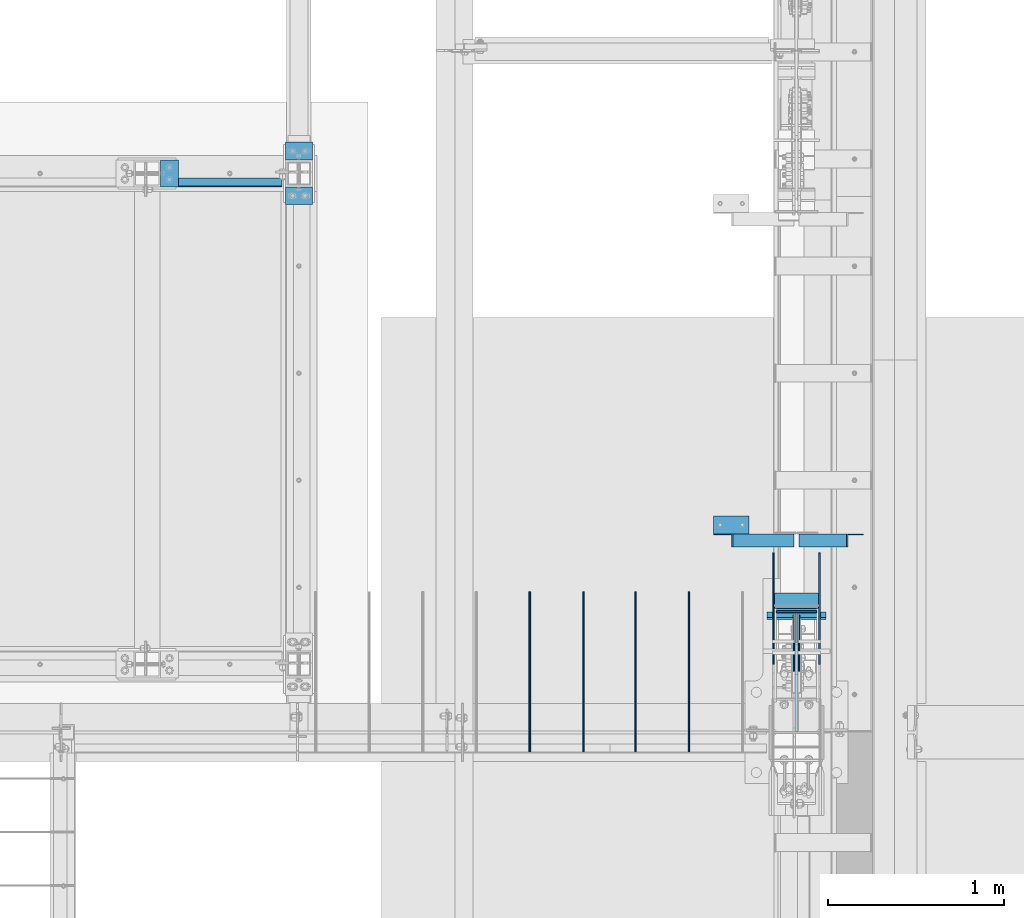
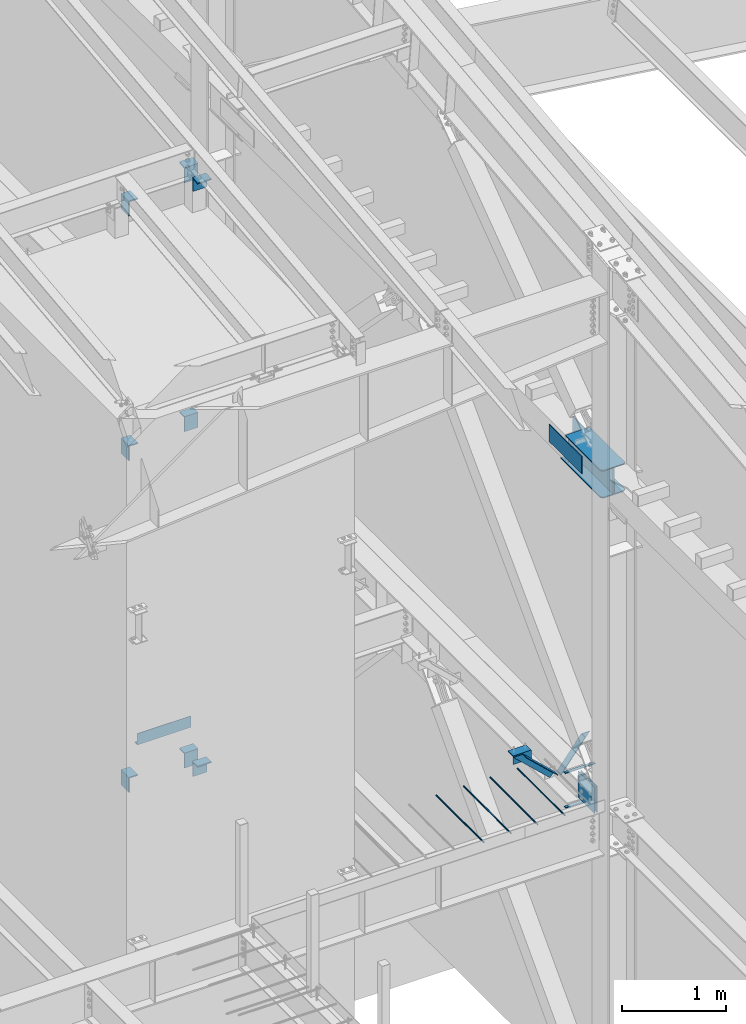
# One storey, part 825 of 1179: 24 beams, 2 members, 20 elements without a shape of their own.
"""IFC2X3 building model written with IfcOpenShell, lengths in millimetres."""

from ifc_helpers import new_model, si_unit, frame, origin_with_axes, place, context, subcontext, project, spatial, faceted_brep, material, type_object, element, aggregate, save


model = new_model("IFC2X3")

# Units and contexts
model_context = context("Model", 3, precision=1e-05, world=origin_with_axes())
body_context = subcontext(model_context, "Body", "Model", "MODEL_VIEW")
ifc_project = project(units=[si_unit("LENGTHUNIT", "METRE", prefix="MILLI"), si_unit("AREAUNIT", "SQUARE_METRE"), si_unit("VOLUMEUNIT", "CUBIC_METRE"), si_unit("MASSUNIT", "GRAM", prefix="KILO"), si_unit("TIMEUNIT", "SECOND"), si_unit("PLANEANGLEUNIT", "RADIAN"), si_unit("SOLIDANGLEUNIT", "STERADIAN"), si_unit("THERMODYNAMICTEMPERATUREUNIT", "DEGREE_CELSIUS"), si_unit("LUMINOUSINTENSITYUNIT", "LUMEN")], contexts=[model_context])

# Site, building, storey
site_placement = place(None, origin_with_axes())
site = spatial("IfcSite", under=ifc_project, at=site_placement, CompositionType="ELEMENT")
building_placement = place(site_placement, origin_with_axes())
building = spatial("IfcBuilding", under=site, at=building_placement, Name="Undefined", CompositionType="ELEMENT")
storey_placement = place(building_placement, origin_with_axes())
storey = spatial("IfcBuildingStorey", under=building, at=storey_placement, Name="Undefined", CompositionType="ELEMENT", Elevation=0.0)

# Assembly, beam
assembly_1_placement = place(storey_placement, origin_with_axes())
assembly_1 = element("IfcElementAssembly", 1, at=assembly_1_placement, inside=storey, Name="BEAM", AssemblyPlace="NOTDEFINED", PredefinedType="RIGID_FRAME")
ifc_material_1 = material(Name="STEEL/A36")
beam_type_1 = type_object("IfcBeamType", PredefinedType="NOTDEFINED")
beam_1_placement = place(assembly_1_placement, frame((21082.0, 14589.125, 4235.45000610352), z_axis=(1.0, 0.0, 0.0), x_axis=(0.0, 0.0, -1.0)))
beam_1 = element("IfcBeam", 2, at=beam_1_placement, type_object=beam_type_1, material=ifc_material_1, Name="BENT_PLATE", context=body_context, shape_type="Brep", body=[
    faceted_brep([(0.0, -3.17499999999927, -298.450000000001), (0.0, -3.17499999999927, 298.450000000001), (0.0, 3.17499999999927, 298.450000000001), (0.0, 3.17499999999927, -298.450000000001), (127.000006103516, 3.17499999999927, 298.450000000001), (127.000006103516, 3.17499999999927, -298.450000000001), (133.350006103517, -3.17499999999927, -298.450000000001), (133.350006103517, -3.17499999999927, 298.450000000001), (127.000006103516, 47.6250007629424, 298.450000000001), (127.000006103516, 47.6250007629424, -298.450000000001), (133.350006103517, 47.6250007629424, 298.450000000001), (133.350006103517, 47.6250007629424, -298.450000000001)], [[[0, 1, 2, 3]], [[3, 2, 4, 5]], [[1, 0, 6, 7]], [[5, 4, 8, 9]], [[4, 2, 1, 7, 10, 8]], [[7, 6, 11, 10]], [[6, 0, 3, 5, 9, 11]], [[10, 11, 9, 8]]]),
])
aggregate(assembly_1, [beam_1])

# Assembly, member
assembly_2_placement = place(storey_placement, origin_with_axes())
assembly_2 = element("IfcElementAssembly", 3, at=assembly_2_placement, inside=storey, Name="ANGLE", AssemblyPlace="NOTDEFINED", PredefinedType="RIGID_FRAME")
member_type = type_object("IfcMemberType", Name="L3X3X1/4", PredefinedType="NOTDEFINED")
member_1_placement = place(assembly_2_placement, frame((23812.1150890972, 12573.0, 4162.88757791506), z_axis=(0.0, -1.0, 0.0), x_axis=(0.729484494811633, 0.0, -0.683997347823379)))
member_1 = element("IfcMember", 4, at=member_1_placement, type_object=member_type, material=ifc_material_1, Name="ANGLE", ObjectType="L3X3X1/4", context=body_context, shape_type="Brep", body=[
    faceted_brep([(148.072119708857, 38.1000000000204, -38.0999999999985), (148.072119708857, 38.1000000000204, 38.0999999999985), (623.824460863128, 38.1000000000349, 38.0999999999985), (623.824460863128, 38.1000000000349, -38.0999999999985), (141.299832423247, 31.7500000000182, 38.0999999999985), (623.824460863128, 31.7500000000291, 38.0999999999985), (141.299832423247, 31.7500000000182, -31.75), (623.824460863128, 31.7500000000291, -31.75), (66.8046722815307, -38.1000000000095, -31.75), (623.824460863132, -38.0999999999913, -31.75), (66.8046722815307, -38.1000000000095, -38.0999999999985), (623.824460863132, -38.0999999999913, -38.0999999999985)], [[[0, 1, 2, 3]], [[1, 4, 5, 2]], [[4, 6, 7, 5]], [[6, 8, 9, 7]], [[8, 10, 11, 9]], [[10, 0, 3, 11]], [[5, 7, 9, 11, 3, 2]], [[10, 8, 6, 4, 1, 0]]]),
])
aggregate(assembly_2, [member_1])

assembly_3_placement = place(storey_placement, origin_with_axes())
assembly_3 = element("IfcElementAssembly", 5, at=assembly_3_placement, inside=storey, Name="ANGLE", AssemblyPlace="NOTDEFINED", PredefinedType="RIGID_FRAME")
member_2_placement = place(assembly_3_placement, frame((24352.3014298031, 12573.0, 3731.6636484264), z_axis=(0.0, -1.0, 0.0), x_axis=(0.614083067285056, 0.0, 0.789241399366365)))
member_2 = element("IfcMember", 6, at=member_2_placement, type_object=member_type, material=ifc_material_1, Name="ANGLE", ObjectType="L3X3X1/4", context=body_context, shape_type="Brep", body=[
    faceted_brep([(0.0, 38.0999999999985, -38.0999999999999), (0.0, 38.0999999999985, 38.0999999999999), (439.713105507173, 38.1000000000386, 38.0999999999985), (439.713105507173, 38.1000000000386, -38.0999999999985), (0.0, 31.75, 38.1000000000004), (444.653834009747, 31.7500000000473, 38.0999999999985), (0.0, 31.75, -31.75), (444.653834009747, 31.7500000000473, -31.75), (0.0, -38.0999999999985, -31.75), (499.001847538042, -38.0999999998749, -31.75), (0.0, -38.0999999999985, -38.0999999999999), (499.001847538042, -38.0999999998749, -38.0999999999985)], [[[0, 1, 2, 3]], [[1, 4, 5, 2]], [[4, 6, 7, 5]], [[6, 8, 9, 7]], [[8, 10, 11, 9]], [[10, 0, 3, 11]], [[5, 7, 9, 11, 3, 2]], [[10, 8, 6, 4, 1, 0]]]),
])
aggregate(assembly_3, [member_2])

# Assembly, beams
assembly_4_placement = place(storey_placement, origin_with_axes())
assembly_4 = element("IfcElementAssembly", 7, at=assembly_4_placement, inside=storey, Name="BEAM", AssemblyPlace="NOTDEFINED", PredefinedType="RIGID_FRAME")
ifc_material_2 = material(Name="STEEL/A572-GR.50")
beam_type_2 = type_object("IfcBeamType", PredefinedType="NOTDEFINED")
beam_2_placement = place(assembly_4_placement, frame((24307.8000366209, 12154.2363331853, 3678.2375), z_axis=(-1.0, 0.0, 0.0), x_axis=(0.0, -1.0, 0.0)))
beam_2 = element("IfcBeam", 8, at=beam_2_placement, type_object=beam_type_2, material=ifc_material_2, Name="PLATE", context=body_context, shape_type="Brep", body=[
    faceted_brep([(0.0, 4.76249999999982, -168.275000000001), (0.0, 4.76250000000073, 168.275), (31.75, 4.76249999999982, 168.275000000001), (31.75, 4.76249999999982, -168.275000000001), (0.0, -4.76250000000073, 168.275), (31.75, -4.76249999999982, 168.275000000001), (0.0, -4.76249999999982, -168.275000000001), (31.75, -4.76249999999982, -168.275000000001)], [[[0, 1, 2, 3]], [[1, 4, 5, 2]], [[4, 6, 7, 5]], [[6, 0, 3, 7]], [[5, 7, 3, 2]], [[6, 4, 1, 0]]]),
])
beam_3_placement = place(assembly_4_placement, frame((24307.8000366209, 12165.3484303229, 4077.8905), z_axis=(-1.0, 0.0, 0.0), x_axis=(0.0, -1.0, 0.0)))
beam_3 = element("IfcBeam", 9, at=beam_3_placement, type_object=beam_type_2, material=ifc_material_2, Name="PLATE", context=body_context, shape_type="Brep", body=[
    faceted_brep([(0.0, 4.76249999999982, -168.275000000001), (0.0, 4.76250000000073, 168.275), (31.75, 4.76249999999982, 168.275000000001), (31.75, 4.76249999999982, -168.275000000001), (0.0, -4.76250000000073, 168.275), (31.75, -4.76249999999982, 168.275000000001), (0.0, -4.76249999999982, -168.275000000001), (31.75, -4.76249999999982, -168.275000000001)], [[[0, 1, 2, 3]], [[1, 4, 5, 2]], [[4, 6, 7, 5]], [[6, 0, 3, 7]], [[5, 7, 3, 2]], [[6, 4, 1, 0]]]),
])
aggregate(assembly_4, [beam_2, beam_3])

# Assembly, beam
assembly_5_placement = place(storey_placement, origin_with_axes())
assembly_5 = element("IfcElementAssembly", 10, at=assembly_5_placement, inside=storey, Name="COLUMN", AssemblyPlace="NOTDEFINED", PredefinedType="RIGID_FRAME")
beam_type_3 = type_object("IfcBeamType", PredefinedType="NOTDEFINED")
beam_4_placement = place(assembly_5_placement, frame((21475.7, 14839.9499984741, 7658.1), z_axis=(1.0, 0.0, 0.0), x_axis=(0.0, -1.0, 0.0)))
beam_4 = element("IfcBeam", 11, at=beam_4_placement, type_object=beam_type_3, material=ifc_material_1, Name="BENT_PLATE", context=body_context, shape_type="Brep", body=[
    faceted_brep([(7.27595761418343e-12, -6.35000000000036, -76.1999999999971), (0.0, -6.35000000000036, 76.2000000000044), (0.0, 6.35000000000036, 76.2000000000044), (-7.27595761418343e-12, 6.35000000000036, -76.1999999999971), (88.8999984741222, 6.34999999999991, 76.2000000000007), (88.8999984741222, 6.34999999999991, -76.2000000000007), (101.599998474123, -6.34999999999991, -76.2000000000007), (101.599998474123, -6.34999999999991, 76.2000000000007), (88.8999984741222, 171.450003051757, 76.2000000000007), (88.8999984741222, 171.450003051757, -76.2000000000007), (101.599998474123, 171.450003051757, 76.2000000000007), (101.599998474123, 171.450003051757, -76.2000000000007)], [[[0, 1, 2, 3]], [[3, 2, 4, 5]], [[1, 0, 6, 7]], [[5, 4, 8, 9]], [[4, 2, 1, 7, 10, 8]], [[7, 6, 11, 10]], [[6, 0, 3, 5, 9, 11]], [[10, 11, 9, 8]]]),
])
aggregate(assembly_5, [beam_4])

assembly_6_placement = place(storey_placement, origin_with_axes())
assembly_6 = element("IfcElementAssembly", 12, at=assembly_6_placement, inside=storey, Name="COLUMN", AssemblyPlace="NOTDEFINED", PredefinedType="RIGID_FRAME")
beam_5_placement = place(assembly_6_placement, frame((20789.8999984741, 14662.15, 7658.1), z_axis=(0.0, 1.0, 0.0), x_axis=(-1.0, 0.0, 0.0)))
beam_5 = element("IfcBeam", 13, at=beam_5_placement, type_object=beam_type_3, material=ifc_material_1, Name="BENT_PLATE", context=body_context, shape_type="Brep", body=[
    faceted_brep([(7.27595761418343e-12, -6.35000000000036, -76.1999999999971), (0.0, -6.35000000000036, 76.2000000000044), (0.0, 6.35000000000036, 76.2000000000044), (-7.27595761418343e-12, 6.35000000000036, -76.1999999999971), (101.599998474123, 6.34999999999991, 76.2000000000007), (101.599998474123, 6.34999999999991, -76.2000000000007), (88.8999984741222, -6.34999999999991, -76.2000000000007), (88.8999984741222, -6.34999999999991, 76.2000000000007), (101.599998474123, -171.450003051757, 76.2000000000007), (101.599998474123, -171.450003051757, -76.2000000000007), (88.8999984741222, -171.450003051757, 76.2000000000007), (88.8999984741222, -171.450003051757, -76.2000000000007)], [[[0, 1, 2, 3]], [[3, 2, 4, 5]], [[1, 0, 6, 7]], [[5, 4, 8, 9]], [[4, 2, 1, 7, 10, 8]], [[7, 6, 11, 10]], [[6, 0, 3, 5, 9, 11]], [[10, 11, 9, 8]]]),
])
aggregate(assembly_6, [beam_5])

# Assembly, beams
assembly_7_placement = place(storey_placement, origin_with_axes())
assembly_7 = element("IfcElementAssembly", 14, at=assembly_7_placement, inside=storey, Name="COLUMN", AssemblyPlace="NOTDEFINED", PredefinedType="RIGID_FRAME")
beam_6_placement = place(assembly_7_placement, frame((21475.7, 14840.6686266753, 10604.4271585818), z_axis=(1.0, 0.0, 0.0), x_axis=(2.37931089941412e-10, -0.993575662698832, -0.113169794965695)))
beam_6 = element("IfcBeam", 15, at=beam_6_placement, type_object=beam_type_3, material=ifc_material_1, Name="BENT_PLATE", context=body_context, shape_type="Brep", body=[
    faceted_brep([(7.27595761418343e-12, -6.35000000000036, -76.1999999999971), (0.0, -6.35000000000036, 76.2000000000044), (0.0, 6.35000000000036, 76.2000000000044), (-7.27595761418343e-12, 6.35000000000036, -76.1999999999971), (90.9468588647287, 6.35000004562426, 76.2000000000007), (90.9468588647287, 6.35000004562426, -76.2000000000007), (102.284159680639, -6.34999994868303, -76.2000000000007), (102.284159680639, -6.34999994868303, 76.2000000000007), (109.787335175104, 171.984030604186, 76.2000000000007), (109.787335175104, 171.984030604186, -76.2000000000007), (122.405964338148, 170.548691604019, 76.2000000000007), (122.405964338148, 170.548691604019, -76.2000000000007)], [[[0, 1, 2, 3]], [[3, 2, 4, 5]], [[1, 0, 6, 7]], [[5, 4, 8, 9]], [[4, 2, 1, 7, 10, 8]], [[7, 6, 11, 10]], [[6, 0, 3, 5, 9, 11]], [[10, 11, 9, 8]]]),
])
beam_7_placement = place(assembly_7_placement, frame((21475.7, 14485.7055089898, 10564.2250390642), z_axis=(1.0, 0.0, 0.0), x_axis=(0.0, 0.993676146336441, 0.112284087038017)))
beam_7 = element("IfcBeam", 16, at=beam_7_placement, type_object=beam_type_3, material=ifc_material_1, Name="BENT_PLATE", context=body_context, shape_type="Brep", body=[
    faceted_brep([(7.27595761418343e-12, -6.35000000000036, -76.1999999999971), (0.0, -6.35000000000036, 76.2000000000044), (0.0, 6.35000000000036, 76.2000000000044), (-7.27595761418343e-12, 6.35000000000036, -76.1999999999971), (101.599998474123, 6.34999999999991, 76.2000000000007), (101.599998474123, 6.34999999999991, -76.2000000000007), (87.3840912620235, -6.35000000880973, -76.2000000000007), (87.3840912620235, -6.35000000880973, 76.2000000000007), (83.5423060723097, -153.454462787842, 76.2000000000007), (83.5423060723097, -153.454462787842, -76.2000000000007), (70.9226190138452, -152.02845488246, 76.2000000000007), (70.9226190138452, -152.02845488246, -76.2000000000007)], [[[0, 1, 2, 3]], [[3, 2, 4, 5]], [[1, 0, 6, 7]], [[5, 4, 8, 9]], [[4, 2, 1, 7, 10, 8]], [[7, 6, 11, 10]], [[6, 0, 3, 5, 9, 11]], [[10, 11, 9, 8]]]),
])
aggregate(assembly_7, [beam_6, beam_7])

# Assembly, beam
assembly_8_placement = place(storey_placement, origin_with_axes())
assembly_8 = element("IfcElementAssembly", 17, at=assembly_8_placement, inside=storey, Name="COLUMN", AssemblyPlace="NOTDEFINED", PredefinedType="RIGID_FRAME")
beam_8_placement = place(assembly_8_placement, frame((20789.8999984741, 14662.15, 10540.9082183146), z_axis=(0.0, 1.0, 0.0), x_axis=(-1.0, 0.0, 0.0)))
beam_8 = element("IfcBeam", 18, at=beam_8_placement, type_object=beam_type_3, material=ifc_material_1, Name="BENT_PLATE", context=body_context, shape_type="Brep", body=[
    faceted_brep([(7.27595761418343e-12, -6.35000000000036, -76.1999999999971), (0.0, -6.35000000000036, 76.2000000000044), (0.0, 6.35000000000036, 76.2000000000044), (-7.27595761418343e-12, 6.35000000000036, -76.1999999999971), (101.599998474123, 6.34999999999991, 76.2000000000007), (101.599998474123, 6.34999999999991, -76.2000000000007), (88.8999984741222, -6.34999999999991, -76.2000000000007), (88.8999984741222, -6.34999999999991, 76.2000000000007), (101.599998474123, -171.450003051757, 76.2000000000007), (101.599998474123, -171.450003051757, -76.2000000000007), (88.8999984741222, -171.450003051757, 76.2000000000007), (88.8999984741222, -171.450003051757, -76.2000000000007)], [[[0, 1, 2, 3]], [[3, 2, 4, 5]], [[1, 0, 6, 7]], [[5, 4, 8, 9]], [[4, 2, 1, 7, 10, 8]], [[7, 6, 11, 10]], [[6, 0, 3, 5, 9, 11]], [[10, 11, 9, 8]]]),
])
aggregate(assembly_8, [beam_8])

assembly_9_placement = place(storey_placement, origin_with_axes())
assembly_9 = element("IfcElementAssembly", 19, at=assembly_9_placement, inside=storey, Name="COLUMN", AssemblyPlace="NOTDEFINED", PredefinedType="RIGID_FRAME")
beam_9_placement = place(assembly_9_placement, frame((20789.8999984741, 14662.15, 3746.5), z_axis=(0.0, 1.0, 0.0), x_axis=(-1.0, 0.0, 0.0)))
beam_9 = element("IfcBeam", 20, at=beam_9_placement, type_object=beam_type_3, material=ifc_material_1, Name="BENT_PLATE", context=body_context, shape_type="Brep", body=[
    faceted_brep([(7.27595761418343e-12, -6.35000000000036, -76.1999999999971), (0.0, -6.35000000000036, 76.2000000000044), (0.0, 6.35000000000036, 76.2000000000044), (-7.27595761418343e-12, 6.35000000000036, -76.1999999999971), (101.599998474123, 6.34999999999991, 76.2000000000007), (101.599998474123, 6.34999999999991, -76.2000000000007), (88.8999984741222, -6.34999999999991, -76.2000000000007), (88.8999984741222, -6.34999999999991, 76.2000000000007), (101.599998474123, -171.450003051757, 76.2000000000007), (101.599998474123, -171.450003051757, -76.2000000000007), (88.8999984741222, -171.450003051757, 76.2000000000007), (88.8999984741222, -171.450003051757, -76.2000000000007)], [[[0, 1, 2, 3]], [[3, 2, 4, 5]], [[1, 0, 6, 7]], [[5, 4, 8, 9]], [[4, 2, 1, 7, 10, 8]], [[7, 6, 11, 10]], [[6, 0, 3, 5, 9, 11]], [[10, 11, 9, 8]]]),
])
aggregate(assembly_9, [beam_9])

# Assembly, beams
assembly_10_placement = place(storey_placement, origin_with_axes())
assembly_10 = element("IfcElementAssembly", 21, at=assembly_10_placement, inside=storey, Name="COLUMN", AssemblyPlace="NOTDEFINED", PredefinedType="RIGID_FRAME")
beam_10_placement = place(assembly_10_placement, frame((21475.6998279452, 14839.9499984741, 3692.52499649481), z_axis=(1.0, 0.0, 0.0), x_axis=(0.0, -1.0, 0.0)))
beam_10 = element("IfcBeam", 22, at=beam_10_placement, type_object=beam_type_3, material=ifc_material_1, Name="BENT_PLATE", context=body_context, shape_type="Brep", body=[
    faceted_brep([(7.27595761418343e-12, -6.35000000000036, -76.1999999999971), (0.0, -6.35000000000036, 76.2000000000044), (0.0, 6.35000000000036, 76.2000000000044), (-7.27595761418343e-12, 6.35000000000036, -76.1999999999971), (88.8999984741222, 6.34999999999991, 76.2000000000007), (88.8999984741222, 6.34999999999991, -76.2000000000007), (101.599998474123, -6.34999999999991, -76.2000000000007), (101.599998474123, -6.34999999999991, 76.2000000000007), (88.8999984741222, 171.450003051757, 76.2000000000007), (88.8999984741222, 171.450003051757, -76.2000000000007), (101.599998474123, 171.450003051757, 76.2000000000007), (101.599998474123, 171.450003051757, -76.2000000000007)], [[[0, 1, 2, 3]], [[3, 2, 4, 5]], [[1, 0, 6, 7]], [[5, 4, 8, 9]], [[4, 2, 1, 7, 10, 8]], [[7, 6, 11, 10]], [[6, 0, 3, 5, 9, 11]], [[10, 11, 9, 8]]]),
])
beam_11_placement = place(assembly_10_placement, frame((21475.699829636, 14484.3500015259, 3692.52499649481), z_axis=(1.0, 0.0, 0.0), x_axis=(0.0, 1.0, 0.0)))
beam_11 = element("IfcBeam", 23, at=beam_11_placement, type_object=beam_type_3, material=ifc_material_1, Name="BENT_PLATE", context=body_context, shape_type="Brep", body=[
    faceted_brep([(7.27595761418343e-12, -6.35000000000036, -76.1999999999971), (0.0, -6.35000000000036, 76.2000000000044), (0.0, 6.35000000000036, 76.2000000000044), (-7.27595761418343e-12, 6.35000000000036, -76.1999999999971), (101.599998474123, 6.34999999999991, 76.2000000000007), (101.599998474123, 6.34999999999991, -76.2000000000007), (88.8999984741222, -6.34999999999991, -76.2000000000007), (88.8999984741222, -6.34999999999991, 76.2000000000007), (101.599998474123, -171.450003051757, 76.2000000000007), (101.599998474123, -171.450003051757, -76.2000000000007), (88.8999984741222, -171.450003051757, 76.2000000000007), (88.8999984741222, -171.450003051757, -76.2000000000007)], [[[0, 1, 2, 3]], [[3, 2, 4, 5]], [[1, 0, 6, 7]], [[5, 4, 8, 9]], [[4, 2, 1, 7, 10, 8]], [[7, 6, 11, 10]], [[6, 0, 3, 5, 9, 11]], [[10, 11, 9, 8]]]),
])
aggregate(assembly_10, [beam_10, beam_11])

# Assembly, beam
assembly_11_placement = place(storey_placement, origin_with_axes())
assembly_11 = element("IfcElementAssembly", 24, at=assembly_11_placement, inside=storey, Name="COLUMN", AssemblyPlace="NOTDEFINED", PredefinedType="RIGID_FRAME")
beam_type_4 = type_object("IfcBeamType", PredefinedType="NOTDEFINED")
beam_12_placement = place(assembly_11_placement, frame((24307.8, 12163.2501974615, 7861.3), z_axis=(0.0, 0.0, 1.0), x_axis=(0.0, -1.0, 0.0)))
beam_12 = element("IfcBeam", 25, at=beam_12_placement, type_object=beam_type_4, material=ifc_material_2, Name="PLATE", context=body_context, shape_type="Brep", body=[
    faceted_brep([(0.0, 9.52500000000146, -152.4), (0.0, 9.52500000000146, 152.4), (676.100196486103, 9.52500000000146, 152.4), (676.100196486103, 9.52500000000146, -152.4), (0.0, -9.52500000000146, 152.4), (676.100196486103, -9.52500000000146, 152.4), (0.0, -9.52500000000146, -152.4), (676.100196486103, -9.52500000000146, -152.4)], [[[0, 1, 2, 3]], [[1, 4, 5, 2]], [[4, 6, 7, 5]], [[6, 0, 3, 7]], [[5, 7, 3, 2]], [[6, 4, 1, 0]]]),
])

assembly_12_placement = place(storey_placement, origin_with_axes())
assembly_12 = element("IfcElementAssembly", 26, at=assembly_12_placement, inside=storey, Name="ANGLE", AssemblyPlace="NOTDEFINED", PredefinedType="RIGID_FRAME")
beam_type_5 = type_object("IfcBeamType", Name="L4X4X1/4", PredefinedType="NOTDEFINED")
beam_13_placement = place(assembly_12_placement, frame((23834.8036446584, 12661.9, 4051.3), z_axis=(0.0, 0.0, -1.0), x_axis=(1.0, 0.0, 0.0)))
beam_13 = element("IfcBeam", 27, at=beam_13_placement, type_object=beam_type_5, material=ifc_material_1, Name="ANGLE", ObjectType="L4X4X1/4", context=body_context, shape_type="Brep", body=[
    faceted_brep([(1.90993887372315e-11, 50.8000000000002, -50.8000000000002), (1.90993887372315e-11, 50.8000000000002, 50.8000000000002), (203.200000000001, 50.7999999999993, 50.8000000000002), (203.200000000001, 50.7999999999993, -50.8000000000002), (0.0, 44.4500000000007, 50.8000000000002), (203.200000000001, 44.4500000000007, 50.8000000000002), (0.0, 44.4500000000007, -44.4499999999998), (203.200000000001, 44.4500000000007, -44.4499999999998), (0.0, -50.7999999999993, -44.4499999999998), (203.200000000001, -50.7999999999993, -44.4499999999998), (-1.81898940354586e-11, -50.7999999999997, -50.8000000000002), (203.200000000001, -50.7999999999993, -50.8000000000002)], [[[0, 1, 2, 3]], [[1, 4, 5, 2]], [[4, 6, 7, 5]], [[6, 8, 9, 7]], [[8, 10, 11, 9]], [[10, 0, 3, 11]], [[5, 7, 9, 11, 3, 2]], [[10, 8, 6, 4, 1, 0]]]),
])
aggregate(assembly_12, [beam_13])

assembly_13_placement = place(storey_placement, origin_with_axes())
assembly_13 = element("IfcElementAssembly", 28, at=assembly_13_placement, inside=storey, Name="PLATE", AssemblyPlace="NOTDEFINED", PredefinedType="RIGID_FRAME")
beam_type_6 = type_object("IfcBeamType", PredefinedType="NOTDEFINED")
beam_14_placement = place(assembly_13_placement, frame((24439.5625, 11867.9751974615, 7861.3), z_axis=(0.0, 0.0, 1.0), x_axis=(0.0, 1.0, 0.0)))
beam_14 = element("IfcBeam", 29, at=beam_14_placement, type_object=beam_type_6, material=ifc_material_2, Name="PLATE", context=body_context, shape_type="Brep", body=[
    faceted_brep([(0.0, 4.76250000000073, -101.6), (0.0, 4.76250000000073, 101.6), (635.0, 4.76250000000073, 101.6), (635.0, 4.76250000000073, -101.6), (0.0, -4.76250000000073, 101.6), (635.0, -4.76250000000073, 101.6), (0.0, -4.76250000000073, -101.6), (635.0, -4.76250000000073, -101.6)], [[[0, 1, 2, 3]], [[1, 4, 5, 2]], [[4, 6, 7, 5]], [[6, 0, 3, 7]], [[5, 7, 3, 2]], [[6, 4, 1, 0]]]),
])
aggregate(assembly_13, [beam_14])

assembly_14_placement = place(storey_placement, origin_with_axes())
assembly_14 = element("IfcElementAssembly", 30, at=assembly_14_placement, inside=storey, Name="PLATE", AssemblyPlace="NOTDEFINED", PredefinedType="RIGID_FRAME")
beam_15_placement = place(assembly_14_placement, frame((24176.0375, 11867.9751974615, 7861.3), z_axis=(0.0, 0.0, 1.0), x_axis=(0.0, 1.0, 0.0)))
beam_15 = element("IfcBeam", 31, at=beam_15_placement, type_object=beam_type_6, material=ifc_material_2, Name="PLATE", context=body_context, shape_type="Brep", body=[
    faceted_brep([(0.0, 4.76250000000073, -101.6), (0.0, 4.76250000000073, 101.6), (635.0, 4.76250000000073, 101.6), (635.0, 4.76250000000073, -101.6), (0.0, -4.76250000000073, 101.6), (635.0, -4.76250000000073, 101.6), (0.0, -4.76250000000073, -101.6), (635.0, -4.76250000000073, -101.6)], [[[0, 1, 2, 3]], [[1, 4, 5, 2]], [[4, 6, 7, 5]], [[6, 0, 3, 7]], [[5, 7, 3, 2]], [[6, 4, 1, 0]]]),
])
aggregate(assembly_14, [beam_15])

# Beam
beam_type_7 = type_object("IfcBeamType", PredefinedType="NOTDEFINED")
beam_16_placement = place(assembly_11_placement, frame((24193.5, 12168.0126974615, 7861.3), z_axis=(0.0, 0.0, 1.0), x_axis=(1.0, 0.0, 0.0)))
beam_16 = element("IfcBeam", 32, at=beam_16_placement, type_object=beam_type_7, material=ifc_material_2, Name="PLATE", context=body_context, shape_type="Brep", body=[
    faceted_brep([(0.0, 4.76250000000073, -152.4), (0.0, 4.76250000000073, 152.4), (228.600000000002, 4.76250000000073, 152.4), (228.600000000002, 4.76250000000073, -152.4), (0.0, -4.76250000000073, 152.4), (228.600000000002, -4.76250000000073, 152.4), (0.0, -4.76250000000073, -152.4), (228.600000000002, -4.76250000000073, -152.4)], [[[0, 1, 2, 3]], [[1, 4, 5, 2]], [[4, 6, 7, 5]], [[6, 0, 3, 7]], [[5, 7, 3, 2]], [[6, 4, 1, 0]]]),
])

beam_type_8 = type_object("IfcBeamType", PredefinedType="NOTDEFINED")
beam_17_placement = place(assembly_11_placement, frame((24307.8, 12274.3751974615, 7702.55), z_axis=(-1.0, 0.0, 0.0), x_axis=(0.0, -1.0, 0.0)))
beam_17 = element("IfcBeam", 33, at=beam_17_placement, type_object=beam_type_8, material=ifc_material_2, Name="PLATE", context=body_context, shape_type="Brep", body=[
    faceted_brep([(765.000197461464, 6.35000000000036, -136.525000000001), (787.225197461465, 6.35000000000036, -114.299999999999), (787.225197461465, -6.35000000000036, -114.299999999999), (765.000197461464, -6.35000000000036, -136.525000000001), (787.225197461465, 6.35000000000036, 114.299999999999), (765.000197461464, 6.35000000000036, 136.525000000001), (765.000197461464, -6.35000000000036, 136.525000000001), (787.225197461465, -6.35000000000036, 114.299999999999), (0.0, 6.35000000000036, -136.525000000001), (0.0, 6.35000000000036, 136.525000000001), (0.0, -6.35000000000036, 136.525000000001), (0.0, -6.35000000000036, -136.525000000001)], [[[0, 1, 2, 3]], [[4, 5, 6, 7]], [[8, 9, 5, 4, 1, 0]], [[9, 10, 6, 5]], [[7, 6, 10, 11, 3, 2]], [[11, 8, 0, 3]], [[4, 7, 2, 1]], [[11, 10, 9, 8]]]),
])

beam_18_placement = place(assembly_11_placement, frame((24307.8, 12185.4751974615, 8020.05), z_axis=(-1.0, 0.0, 0.0), x_axis=(0.0, -1.0, 0.0)))
beam_18 = element("IfcBeam", 34, at=beam_18_placement, type_object=beam_type_8, material=ifc_material_2, Name="PLATE", context=body_context, shape_type="Brep", body=[
    faceted_brep([(676.100197461472, 6.35000000000036, -136.525000000001), (698.325197461472, 6.35000000000036, -114.299999999999), (698.325197461472, -6.35000000000036, -114.299999999999), (676.100197461472, -6.35000000000036, -136.525000000001), (698.325197461472, 6.35000000000036, 114.299999999999), (676.100197461472, 6.35000000000036, 136.525000000001), (676.100197461472, -6.35000000000036, 136.525000000001), (698.325197461472, -6.35000000000036, 114.299999999999), (0.0, 6.35000000000036, -136.525000000001), (0.0, 6.35000000000036, 136.525000000001), (0.0, -6.35000000000036, 136.525000000001), (0.0, -6.35000000000036, -136.525000000001)], [[[0, 1, 2, 3]], [[4, 5, 6, 7]], [[8, 9, 5, 4, 1, 0]], [[9, 10, 6, 5]], [[7, 6, 10, 11, 3, 2]], [[11, 8, 0, 3]], [[4, 7, 2, 1]], [[11, 10, 9, 8]]]),
])

aggregate(assembly_11, [beam_12, beam_16, beam_17, beam_18])

# Assembly, beam
assembly_15_placement = place(storey_placement, origin_with_axes())
assembly_15 = element("IfcElementAssembly", 35, at=assembly_15_placement, inside=storey, Name="PLATE", AssemblyPlace="NOTDEFINED", PredefinedType="RIGID_FRAME")
beam_type_9 = type_object("IfcBeamType", PredefinedType="NOTDEFINED")
beam_19_placement = place(assembly_15_placement, frame((24293.5125, 12146.2984333746, 3892.55), z_axis=(0.0, 0.0, -1.0), x_axis=(0.0, -1.0, 0.0)))
beam_19 = element("IfcBeam", 36, at=beam_19_placement, type_object=beam_type_9, material=ifc_material_2, Name="PLATE", context=body_context, shape_type="Brep", body=[
    faceted_brep([(0.0, 4.76250000000073, -152.4), (0.0, 4.76250000000073, 152.4), (317.5, 4.76250000000073, 152.4), (317.5, 4.76250000000073, -152.4), (0.0, -4.76250000000073, 152.4), (317.5, -4.76250000000073, 152.4), (0.0, -4.76250000000073, -152.4), (317.5, -4.76250000000073, -152.4)], [[[0, 1, 2, 3]], [[1, 4, 5, 2]], [[4, 6, 7, 5]], [[6, 0, 3, 7]], [[5, 7, 3, 2]], [[6, 4, 1, 0]]]),
])
aggregate(assembly_15, [beam_19])

assembly_16_placement = place(storey_placement, origin_with_axes())
assembly_16 = element("IfcElementAssembly", 37, at=assembly_16_placement, inside=storey, Name="PLATE", AssemblyPlace="NOTDEFINED", PredefinedType="RIGID_FRAME")
beam_20_placement = place(assembly_16_placement, frame((24322.0875, 11828.7984333746, 3892.55), z_axis=(0.0, 0.0, -1.0), x_axis=(0.0, 1.0, 0.0)))
beam_20 = element("IfcBeam", 38, at=beam_20_placement, type_object=beam_type_9, material=ifc_material_2, Name="PLATE", context=body_context, shape_type="Brep", body=[
    faceted_brep([(0.0, 4.76250000000073, -152.4), (0.0, 4.76250000000073, 152.4), (317.5, 4.76250000000073, 152.4), (317.5, 4.76250000000073, -152.4), (0.0, -4.76250000000073, 152.4), (317.5, -4.76250000000073, 152.4), (0.0, -4.76250000000073, -152.4), (317.5, -4.76250000000073, -152.4)], [[[0, 1, 2, 3]], [[1, 4, 5, 2]], [[4, 6, 7, 5]], [[6, 0, 3, 7]], [[5, 7, 3, 2]], [[6, 4, 1, 0]]]),
])
aggregate(assembly_16, [beam_20])

assembly_17_placement = place(storey_placement, origin_with_axes())
assembly_17 = element("IfcElementAssembly", 39, at=assembly_17_placement, inside=storey, Name="#4 DOWEL", AssemblyPlace="NOTDEFINED", PredefinedType="NOTDEFINED")
ifc_material_3 = material(Name="REBAR/A615-40")
beam_type_10 = type_object("IfcBeamType", Name="#4 DOWEL", PredefinedType="NOTDEFINED")
beam_21_placement = place(assembly_17_placement, frame((23695.819, 11369.675, 4203.70000610352), z_axis=(0.0, 0.0, 1.0), x_axis=(0.0, 1.0, 0.0)))
beam_21 = element("IfcBeam", 40, at=beam_21_placement, type_object=beam_type_10, material=ifc_material_3, Name="#4 DOWEL", ObjectType="#4 DOWEL", context=body_context, shape_type="Brep", body=[
    faceted_brep([(0.0, -6.34999999999854, 0.0), (0.0, -4.49012806053361, -4.49012806053452), (914.399999999994, -4.49012806053452, -4.49012806042992), (914.399999999994, -6.34999999999991, 1.0550138540566e-10), (0.0, 0.0, -6.34999999999991), (914.399999999994, 0.0, -6.34999999989668), (0.0, 4.49012806053361, -4.49012806053452), (914.399999999994, 4.49012806053452, -4.49012806042992), (0.0, 6.34999999999854, 0.0), (914.399999999994, 6.34999999999991, 1.0550138540566e-10), (0.0, 4.49012806053361, 4.49012806053452), (914.399999999995, 4.49012806053452, 4.49012806064184), (0.0, 0.0, 6.34999999999991), (914.399999999995, 0.0, 6.35000000010768), (0.0, -4.49012806053361, 4.49012806053452), (914.399999999995, -4.49012806053452, 4.49012806064184)], [[[0, 1, 2, 3]], [[1, 4, 5, 2]], [[4, 6, 7, 5]], [[6, 8, 9, 7]], [[8, 10, 11, 9]], [[10, 12, 13, 11]], [[12, 14, 15, 13]], [[14, 0, 3, 15]], [[5, 7, 9, 11, 13, 15, 3, 2]], [[14, 12, 10, 8, 6, 4, 1, 0]]]),
])
aggregate(assembly_17, [beam_21])

assembly_18_placement = place(storey_placement, origin_with_axes())
assembly_18 = element("IfcElementAssembly", 41, at=assembly_18_placement, inside=storey, Name="#4 DOWEL", AssemblyPlace="NOTDEFINED", PredefinedType="NOTDEFINED")
beam_22_placement = place(assembly_18_placement, frame((23391.019, 11369.675, 4203.70000610352), z_axis=(0.0, 0.0, 1.0), x_axis=(0.0, 1.0, 0.0)))
beam_22 = element("IfcBeam", 42, at=beam_22_placement, type_object=beam_type_10, material=ifc_material_3, Name="#4 DOWEL", ObjectType="#4 DOWEL", context=body_context, shape_type="Brep", body=[
    faceted_brep([(0.0, -6.34999999999854, 0.0), (0.0, -4.49012806053361, -4.49012806053452), (914.399999999994, -4.49012806053452, -4.49012806042992), (914.399999999994, -6.34999999999991, 1.0550138540566e-10), (0.0, 0.0, -6.34999999999991), (914.399999999994, 0.0, -6.34999999989668), (0.0, 4.49012806053361, -4.49012806053452), (914.399999999994, 4.49012806053452, -4.49012806042992), (0.0, 6.34999999999854, 0.0), (914.399999999994, 6.34999999999991, 1.0550138540566e-10), (0.0, 4.49012806053361, 4.49012806053452), (914.399999999995, 4.49012806053452, 4.49012806064184), (0.0, 0.0, 6.34999999999991), (914.399999999995, 0.0, 6.35000000010768), (0.0, -4.49012806053361, 4.49012806053452), (914.399999999995, -4.49012806053452, 4.49012806064184)], [[[0, 1, 2, 3]], [[1, 4, 5, 2]], [[4, 6, 7, 5]], [[6, 8, 9, 7]], [[8, 10, 11, 9]], [[10, 12, 13, 11]], [[12, 14, 15, 13]], [[14, 0, 3, 15]], [[5, 7, 9, 11, 13, 15, 3, 2]], [[14, 12, 10, 8, 6, 4, 1, 0]]]),
])
aggregate(assembly_18, [beam_22])

assembly_19_placement = place(storey_placement, origin_with_axes())
assembly_19 = element("IfcElementAssembly", 43, at=assembly_19_placement, inside=storey, Name="#4 DOWEL", AssemblyPlace="NOTDEFINED", PredefinedType="NOTDEFINED")
beam_23_placement = place(assembly_19_placement, frame((23094.95, 11369.675, 4203.70000610352), z_axis=(0.0, 0.0, 1.0), x_axis=(0.0, 1.0, 0.0)))
beam_23 = element("IfcBeam", 44, at=beam_23_placement, type_object=beam_type_10, material=ifc_material_3, Name="#4 DOWEL", ObjectType="#4 DOWEL", context=body_context, shape_type="Brep", body=[
    faceted_brep([(0.0, -6.34999999999854, 0.0), (0.0, -4.49012806053361, -4.49012806053452), (914.399999999994, -4.49012806053452, -4.49012806042992), (914.399999999994, -6.34999999999991, 1.0550138540566e-10), (0.0, 0.0, -6.34999999999991), (914.399999999994, 0.0, -6.34999999989668), (0.0, 4.49012806053361, -4.49012806053452), (914.399999999994, 4.49012806053452, -4.49012806042992), (0.0, 6.34999999999854, 0.0), (914.399999999994, 6.34999999999991, 1.0550138540566e-10), (0.0, 4.49012806053361, 4.49012806053452), (914.399999999995, 4.49012806053452, 4.49012806064184), (0.0, 0.0, 6.34999999999991), (914.399999999995, 0.0, 6.35000000010768), (0.0, -4.49012806053361, 4.49012806053452), (914.399999999995, -4.49012806053452, 4.49012806064184)], [[[0, 1, 2, 3]], [[1, 4, 5, 2]], [[4, 6, 7, 5]], [[6, 8, 9, 7]], [[8, 10, 11, 9]], [[10, 12, 13, 11]], [[12, 14, 15, 13]], [[14, 0, 3, 15]], [[5, 7, 9, 11, 13, 15, 3, 2]], [[14, 12, 10, 8, 6, 4, 1, 0]]]),
])
aggregate(assembly_19, [beam_23])

assembly_20_placement = place(storey_placement, origin_with_axes())
assembly_20 = element("IfcElementAssembly", 45, at=assembly_20_placement, inside=storey, Name="#4 DOWEL", AssemblyPlace="NOTDEFINED", PredefinedType="NOTDEFINED")
beam_24_placement = place(assembly_20_placement, frame((22790.15, 11369.675, 4203.70000610352), z_axis=(0.0, 0.0, 1.0), x_axis=(0.0, 1.0, 0.0)))
beam_24 = element("IfcBeam", 46, at=beam_24_placement, type_object=beam_type_10, material=ifc_material_3, Name="#4 DOWEL", ObjectType="#4 DOWEL", context=body_context, shape_type="Brep", body=[
    faceted_brep([(0.0, -6.34999999999854, 0.0), (0.0, -4.49012806053361, -4.49012806053452), (914.399999999994, -4.49012806053452, -4.49012806042992), (914.399999999994, -6.34999999999991, 1.0550138540566e-10), (0.0, 0.0, -6.34999999999991), (914.399999999994, 0.0, -6.34999999989668), (0.0, 4.49012806053361, -4.49012806053452), (914.399999999994, 4.49012806053452, -4.49012806042992), (0.0, 6.34999999999854, 0.0), (914.399999999994, 6.34999999999991, 1.0550138540566e-10), (0.0, 4.49012806053361, 4.49012806053452), (914.399999999995, 4.49012806053452, 4.49012806064184), (0.0, 0.0, 6.34999999999991), (914.399999999995, 0.0, 6.35000000010768), (0.0, -4.49012806053361, 4.49012806053452), (914.399999999995, -4.49012806053452, 4.49012806064184)], [[[0, 1, 2, 3]], [[1, 4, 5, 2]], [[4, 6, 7, 5]], [[6, 8, 9, 7]], [[8, 10, 11, 9]], [[10, 12, 13, 11]], [[12, 14, 15, 13]], [[14, 0, 3, 15]], [[5, 7, 9, 11, 13, 15, 3, 2]], [[14, 12, 10, 8, 6, 4, 1, 0]]]),
])
aggregate(assembly_20, [beam_24])

save(model, "model.ifc")
